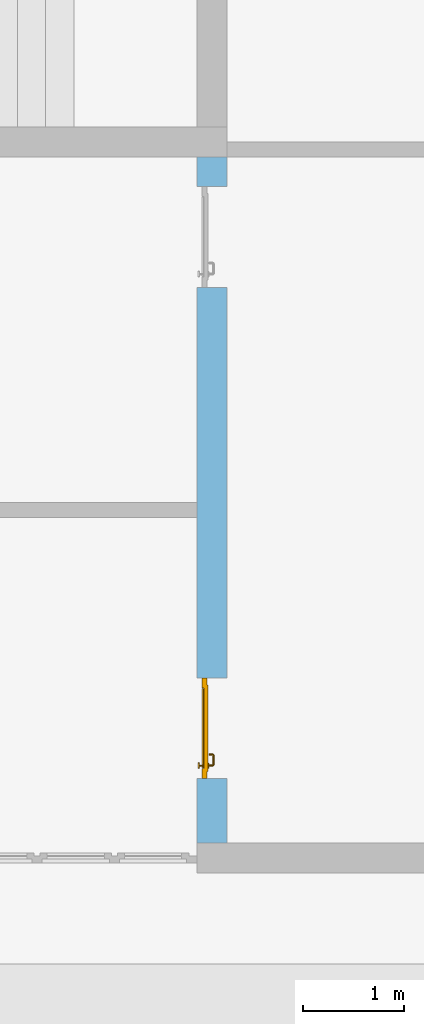
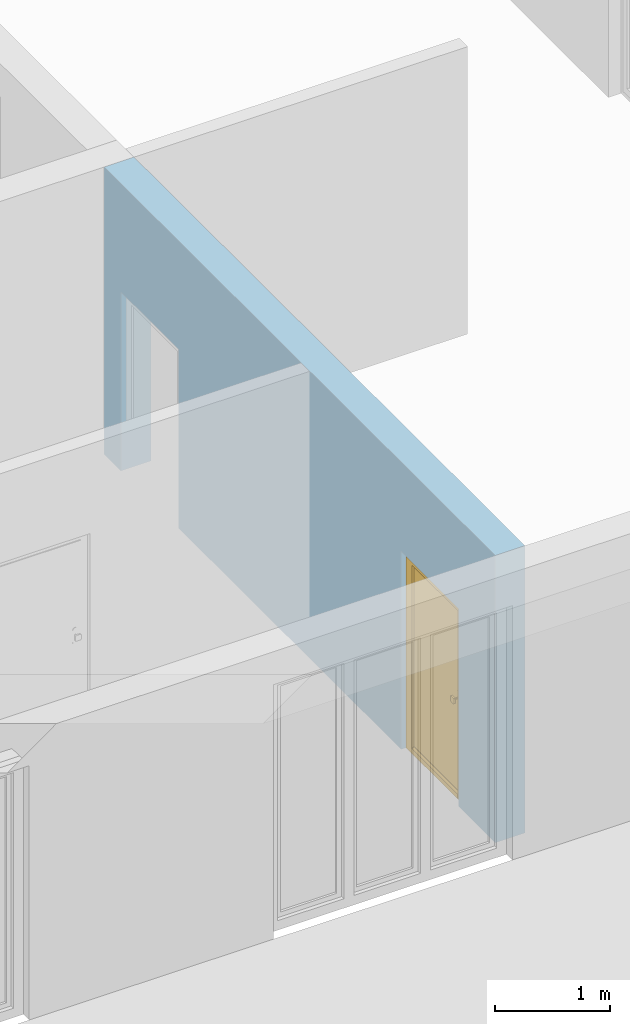
# One storey, part 8 of 23: 1 door, 2 openings, plus 1 element that does not belong to this part.
"""IFC4 building model written with IfcOpenShell, lengths in metres."""

from ifc_helpers import new_model, entity, si_unit, converted_unit, derived_unit, direction, frame, origin_with_axes, place, context, subcontext, project, spatial, polygons, source, transform, mapped, material, type_object, element, fill, save


model = new_model("IFC4")

# Units and contexts
model_context = context("Model", 3, precision=1e-05, world=origin_with_axes(), true_north=direction((0.0, 1.0)))
body_context = subcontext(model_context, "Body", "Model", "MODEL_VIEW")
ifc_project = project(units=[si_unit("LENGTHUNIT", "METRE"), si_unit("AREAUNIT", "SQUARE_METRE"), si_unit("VOLUMEUNIT", "CUBIC_METRE"), converted_unit("PLANEANGLEUNIT", "DEGREE", entity("IfcPlaneAngleMeasure", 0.0174532925199), si_unit("PLANEANGLEUNIT", "RADIAN"), dimensions=[0, 0, 0, 0, 0, 0, 0]), converted_unit("TIMEUNIT", "Year", entity("IfcTimeMeasure", 31556926.0), si_unit("TIMEUNIT", "SECOND"), dimensions=[0, 0, 1, 0, 0, 0, 0]), si_unit("MASSUNIT", "GRAM", prefix="KILO"), si_unit("THERMODYNAMICTEMPERATUREUNIT", "DEGREE_CELSIUS"), si_unit("LUMINOUSINTENSITYUNIT", "LUMEN"), si_unit("ENERGYUNIT", "JOULE", prefix="MEGA"), derived_unit("THERMALCONDUCTANCEUNIT", [(si_unit("POWERUNIT", "WATT"), 1), (si_unit("LENGTHUNIT", "METRE"), -1), (si_unit("THERMODYNAMICTEMPERATUREUNIT", "KELVIN"), -1)]), derived_unit("SPECIFICHEATCAPACITYUNIT", [(si_unit("ENERGYUNIT", "JOULE"), 1), (si_unit("MASSUNIT", "GRAM", prefix="KILO"), -1), (si_unit("THERMODYNAMICTEMPERATUREUNIT", "KELVIN"), -1)]), derived_unit("MASSDENSITYUNIT", [(si_unit("MASSUNIT", "GRAM", prefix="KILO"), 1), (si_unit("VOLUMEUNIT", "CUBIC_METRE"), -1)])], contexts=[model_context])

# Site, building, storey
site_placement = place(None, origin_with_axes())
site = spatial("IfcSite", under=ifc_project, at=site_placement, CompositionType="ELEMENT")
building_placement = place(site_placement, origin_with_axes())
building = spatial("IfcBuilding", under=site, at=building_placement, CompositionType="ELEMENT")
storey_placement = place(building_placement, origin_with_axes())
storey = spatial("IfcBuildingStorey", under=building, at=storey_placement, Name="0. Geschoss", CompositionType="ELEMENT", Elevation=0.0)

# Wall, openings, door
ifc_material = material()
wall_type = type_object("IfcWallType", Name="300", PredefinedType="NOTDEFINED")
wall_placement = place(storey_placement, frame((2.6878006196, -2.52881223104, 0.0), z_axis=(0.0, 0.0, 1.0), x_axis=(0.0, -1.0, 0.0)))
wall = element("IfcWall", 1, at=wall_placement, inside=storey, type_object=wall_type, material=ifc_material, Name="Wand-001", PredefinedType="NOTDEFINED", context=body_context, shape_type="Tessellation", body=[
    polygons([(6.46366655835, 0.15, 0.0), (6.46366655835, 0.15, 2.1), (5.46366655835, 0.15, 2.1), (5.46366655835, 0.15, 0.0), (1.59031106762, 0.15, 0.0), (1.59031106762, 0.15, 1.9), (0.590311067622, 0.15, 1.9), (0.590311067622, 0.15, 0.0), (0.3, 0.15, 0.0), (0.3, 0.15, 3.05), (7.1, 0.15, 3.05), (7.1, 0.15, 0.0), (6.46366655835, -0.1, 0.0), (6.46366655835, -0.15, 0.0), (6.46366655835, -0.15, 2.1), (5.46366655835, -0.15, 2.1), (5.46366655835, -0.1, 0.0), (5.46366655835, -0.15, 0.0), (1.59031106762, -0.15, 0.0), (1.59031106762, -0.15, 1.9), (0.590311067622, -0.15, 1.9), (0.590311067622, -0.15, 0.0), (0.3, -0.15, 0.0), (0.3, -0.15, 3.05), (7.1, -0.15, 3.05), (7.1, -0.15, 0.0)], [[[1, 2, 3, 4, 5, 6, 7, 8, 9, 10, 11, 12]], [[2, 1, 13, 14, 15]], [[3, 2, 15, 16]], [[17, 4, 3, 16, 18]], [[4, 17, 18, 19, 5]], [[19, 20, 6, 5]], [[20, 21, 7, 6]], [[21, 22, 8, 7]], [[23, 9, 8, 22]], [[23, 24, 10, 9]], [[25, 11, 10, 24]], [[12, 11, 25, 26]], [[13, 1, 12, 26, 14]], [[19, 18, 16, 15, 14, 26, 25, 24, 23, 22, 21, 20]]], closed=True),
])
opening_1_placement = place(wall_placement, frame((1.09031106762, 0.0, 0.0), z_axis=(0.0, 0.0, 1.0), x_axis=(1.0, 0.0, 0.0)))
element("IfcOpeningElement", 2, at=opening_1_placement, cuts=wall, context=body_context, identifier="Reference", shape_type="Tessellation", body=[
    polygons([(0.5, -0.1, 0.0), (0.5, -0.1, 1.9), (0.5, -0.151, 1.9), (0.5, -0.151, 0.0), (0.5, 0.151, 0.0), (0.5, 0.151, 1.9), (-0.5, -0.1, 1.9), (-0.5, -0.151, 1.9), (-0.5, 0.151, 1.9), (-0.5, -0.151, 0.0), (-0.5, -0.1, 0.0), (-0.5, 0.151, 0.0)], [[[1, 2, 3, 4]], [[2, 1, 5, 6]], [[7, 8, 3, 2, 6, 9]], [[8, 10, 4, 3]], [[1, 4, 10, 11, 12, 5]], [[6, 5, 12, 9]], [[7, 11, 10, 8]], [[11, 7, 9, 12]]], closed=True),
])
opening_2_placement = place(wall_placement, frame((5.96366655835, 0.0, 0.0), z_axis=(0.0, 0.0, 1.0), x_axis=(1.0, 0.0, 0.0)))
opening_2 = element("IfcOpeningElement", 3, at=opening_2_placement, cuts=wall, context=body_context, identifier="Reference", shape_type="Tessellation", body=[
    polygons([(0.5, -0.1, 0.0), (0.5, -0.1, 2.1), (0.5, -0.151, 2.1), (0.5, -0.151, 0.0), (0.5, 0.151, 0.0), (0.5, 0.151, 2.1), (-0.5, -0.1, 2.1), (-0.5, -0.151, 2.1), (-0.5, 0.151, 2.1), (-0.5, -0.151, 0.0), (-0.5, -0.1, 0.0), (-0.5, 0.151, 0.0)], [[[1, 2, 3, 4]], [[2, 1, 5, 6]], [[7, 8, 3, 2, 6, 9]], [[8, 10, 4, 3]], [[1, 4, 10, 11, 12, 5]], [[6, 5, 12, 9]], [[7, 11, 10, 8]], [[11, 7, 9, 12]]], closed=True),
])
door_type = type_object("IfcDoorType", Name="Eingang 01 1-Fl 26", OperationType="SINGLE_SWING_LEFT", PredefinedType="DOOR")
shared_shape = source(origin_with_axes(), body_context, "Body", "Tessellation", [
    polygons([(-0.5, -0.05, 0.0), (-0.5, -0.05, 2.1), (-0.5, -0.03, 2.1), (-0.5, -0.03, 0.0), (-0.4, -0.05, 0.0), (-0.4, -0.05, 2.0), (-0.1301, -0.05, 2.0), (-0.0001, -0.05, 2.0), (0.4, -0.05, 2.0), (0.4, -0.05, 0.0), (0.5, -0.05, 0.0), (0.5, -0.05, 2.1), (0.5, -0.03, 2.1), (0.5, -0.03, 0.0), (0.4, -0.03, 0.0), (0.4, -0.03, 2.0), (-0.0001, -0.03, 2.0), (-0.1301, -0.03, 2.0), (-0.4, -0.03, 2.0), (-0.4, -0.03, 0.0)], [[[1, 2, 3, 4]], [[1, 5, 6, 7, 8, 9, 10, 11, 12, 2]], [[2, 12, 13, 3]], [[4, 3, 13, 14, 15, 16, 17, 18, 19, 20]], [[5, 1, 4, 20]], [[6, 5, 20, 19]], [[7, 6, 19, 18]], [[8, 7, 18, 17]], [[9, 8, 17, 16]], [[10, 9, 16, 15]], [[11, 10, 15, 14]], [[12, 11, 14, 13]]], closed=True),
    polygons([(-0.5, -0.03, 0.0), (-0.5, -0.03, 2.1), (-0.5, 0.0, 2.1), (-0.5, 0.0, 0.0), (-0.43, -0.03, 0.0), (-0.43, -0.03, 2.03), (-0.1001, -0.03, 2.03), (-0.0301, -0.03, 2.03), (0.43, -0.03, 2.03), (0.43, -0.03, 0.0), (0.5, -0.03, 0.0), (0.5, -0.03, 2.1), (0.5, 0.0, 2.1), (0.5, 0.0, 0.0), (0.43, 0.0, 0.0), (0.43, 0.0, 2.03), (-0.0301, 0.0, 2.03), (-0.1001, 0.0, 2.03), (-0.43, 0.0, 2.03), (-0.43, 0.0, 0.0)], [[[1, 2, 3, 4]], [[1, 5, 6, 7, 8, 9, 10, 11, 12, 2]], [[2, 12, 13, 3]], [[4, 3, 13, 14, 15, 16, 17, 18, 19, 20]], [[5, 1, 4, 20]], [[6, 5, 20, 19]], [[7, 6, 19, 18]], [[8, 7, 18, 17]], [[9, 8, 17, 16]], [[10, 9, 16, 15]], [[11, 10, 15, 14]], [[12, 11, 14, 13]]], closed=True),
    polygons([(-0.43, 0.01, 0.0), (-0.43, 0.01, 2.03), (0.43, 0.01, 2.03), (0.43, 0.01, 0.0), (-0.43, -0.03, 0.0), (-0.43, -0.03, 2.03), (0.43, -0.03, 2.03), (0.43, -0.03, 0.0)], [[[1, 2, 3, 4]], [[1, 5, 6, 2]], [[2, 6, 7, 3]], [[3, 7, 8, 4]], [[4, 8, 5, 1]], [[8, 7, 6, 5]]], closed=True),
    polygons([(-0.395, -0.05, 0.0), (0.395, -0.05, 0.0), (0.395, -0.05, 0.05), (-0.395, -0.05, 0.05), (-0.395, -0.03, 0.0), (0.395, -0.03, 0.0), (0.395, -0.03, 0.07), (0.395, -0.035, 0.07), (-0.395, -0.035, 0.07), (-0.395, -0.03, 0.07)], [[[1, 2, 3, 4]], [[5, 6, 2, 1]], [[2, 6, 7, 8, 3]], [[4, 3, 8, 9]], [[1, 4, 9, 10, 5]], [[10, 7, 6, 5]], [[9, 8, 7, 10]]], closed=True),
    polygons([(0.3835, 0.02, 1.0733826859), (0.37, 0.02, 1.077), (0.37, 0.0199, 1.077), (0.3835, 0.0199, 1.0733826859), (0.393382685902, 0.02, 1.0635), (0.397, 0.02, 1.05), (0.393382685902, 0.02, 1.0365), (0.3835, 0.02, 1.0266173141), (0.37, 0.02, 1.023), (0.3565, 0.02, 1.0266173141), (0.346617314098, 0.02, 1.0365), (0.343, 0.02, 1.05), (0.346617314098, 0.02, 1.0635), (0.3565, 0.02, 1.0733826859), (0.3565, 0.0199, 1.0733826859), (0.37, 0.0101, 1.077), (0.3835, 0.0101, 1.0733826859), (0.393382685902, 0.0199, 1.0635), (0.397, 0.0199, 1.05), (0.393382685902, 0.0199, 1.0365), (0.3835, 0.0199, 1.0266173141), (0.37, 0.0199, 1.023), (0.3565, 0.0199, 1.0266173141), (0.346617314098, 0.0199, 1.0365), (0.343, 0.0199, 1.05), (0.346617314098, 0.0199, 1.0635), (0.3565, 0.0101, 1.0733826859), (0.37, 0.01, 1.077), (0.3835, 0.01, 1.0733826859), (0.393382685902, 0.0101, 1.0635), (0.397, 0.0101, 1.05), (0.393382685902, 0.0101, 1.0365), (0.3835, 0.0101, 1.0266173141), (0.37, 0.0101, 1.023), (0.3565, 0.0101, 1.0266173141), (0.346617314098, 0.0101, 1.0365), (0.343, 0.0101, 1.05), (0.346617314098, 0.0101, 1.0635), (0.3565, 0.01, 1.0733826859), (0.346617314098, 0.01, 1.0635), (0.343, 0.01, 1.05), (0.346617314098, 0.01, 1.0365), (0.3565, 0.01, 1.0266173141), (0.37, 0.01, 1.023), (0.3835, 0.01, 1.0266173141), (0.393382685902, 0.01, 1.0365), (0.397, 0.01, 1.05), (0.393382685902, 0.01, 1.0635)], [[[1, 2, 3, 4]], [[2, 1, 5, 6, 7, 8, 9, 10, 11, 12, 13, 14]], [[2, 14, 15, 3]], [[4, 3, 16, 17]], [[5, 1, 4, 18]], [[6, 5, 18, 19]], [[7, 6, 19, 20]], [[8, 7, 20, 21]], [[9, 8, 21, 22]], [[10, 9, 22, 23]], [[11, 10, 23, 24]], [[12, 11, 24, 25]], [[13, 12, 25, 26]], [[14, 13, 26, 15]], [[3, 15, 27, 16]], [[17, 16, 28, 29]], [[18, 4, 17, 30]], [[19, 18, 30, 31]], [[20, 19, 31, 32]], [[21, 20, 32, 33]], [[22, 21, 33, 34]], [[23, 22, 34, 35]], [[24, 23, 35, 36]], [[25, 24, 36, 37]], [[26, 25, 37, 38]], [[15, 26, 38, 27]], [[16, 27, 39, 28]], [[28, 39, 40, 41, 42, 43, 44, 45, 46, 47, 48, 29]], [[30, 17, 29, 48]], [[31, 30, 48, 47]], [[32, 31, 47, 46]], [[33, 32, 46, 45]], [[34, 33, 45, 44]], [[35, 34, 44, 43]], [[36, 35, 43, 42]], [[37, 36, 42, 41]], [[38, 37, 41, 40]], [[27, 38, 40, 39]]], closed=True),
    polygons([(0.362532169224, 0.019, 0.959692280177), (0.363279754556, 0.019, 0.961639806549), (0.35705, 0.019, 0.972430057958), (0.347569942042, 0.019, 0.96295), (0.365, 0.019, 0.952886751346), (0.365, 0.019, 0.9544), (0.362532169224, 0.02, 0.959692280177), (0.363279754556, 0.02, 0.961639806549), (0.364624817685, 0.02, 0.965143815798), (0.364624817685, 0.019, 0.965143815798), (0.37, 0.019, 0.967425445323), (0.37, 0.019, 0.9759), (0.357, 0.019, 0.972516660498), (0.347483339502, 0.019, 0.963), (0.365, 0.019, 0.95), (0.3441, 0.019, 0.95), (0.365, 0.019, 0.947113248654), (0.365, 0.019, 0.941339745962), (0.365, 0.019, 0.9375), (0.365, 0.02, 0.9375), (0.365, 0.02, 0.941339745962), (0.365, 0.02, 0.947113248654), (0.365, 0.02, 0.95), (0.365, 0.02, 0.952886751346), (0.365, 0.02, 0.9544), (0.346703916638, 0.02, 0.96345), (0.35655, 0.02, 0.973296083362), (0.37, 0.02, 0.9769), (0.37, 0.02, 0.967425445323), (0.375375182315, 0.019, 0.965143815798), (0.376720245444, 0.019, 0.961639806549), (0.38295, 0.019, 0.972430057958), (0.37, 0.019, 0.976), (0.357, 0.0189, 0.972516660498), (0.347483339502, 0.0189, 0.963), (0.344, 0.019, 0.95), (0.347569942042, 0.019, 0.93705), (0.35705, 0.019, 0.927569942042), (0.37, 0.019, 0.9241), (0.37, 0.019, 0.9325), (0.366464466094, 0.019, 0.933964466094), (0.366464466094, 0.02, 0.933964466094), (0.37, 0.02, 0.9231), (0.35655, 0.02, 0.926703916638), (0.37, 0.02, 0.9325), (0.346703916638, 0.02, 0.93655), (0.3431, 0.02, 0.95), (0.346617314098, 0.02, 0.9635), (0.3565, 0.02, 0.973382685902), (0.37, 0.02, 0.977), (0.375375182315, 0.02, 0.965143815798), (0.38345, 0.02, 0.973296083362), (0.376720245444, 0.02, 0.961639806549), (0.377467830776, 0.02, 0.959692280177), (0.377467830776, 0.019, 0.959692280177), (0.375, 0.019, 0.9544), (0.375, 0.019, 0.952886751346), (0.392430057958, 0.019, 0.96295), (0.383, 0.019, 0.972516660498), (0.37, 0.0189, 0.976), (0.357, 0.0101, 0.972516660498), (0.347483339502, 0.0101, 0.963), (0.344, 0.0189, 0.95), (0.347483339502, 0.019, 0.937), (0.357, 0.019, 0.927483339502), (0.37, 0.019, 0.924), (0.38295, 0.019, 0.927569942042), (0.375, 0.019, 0.941339745962), (0.375, 0.019, 0.9375), (0.373535533906, 0.019, 0.933964466094), (0.37, 0.02, 0.923), (0.3565, 0.02, 0.926617314098), (0.38345, 0.02, 0.926703916638), (0.373535533906, 0.02, 0.933964466094), (0.375, 0.02, 0.9375), (0.375, 0.02, 0.941339745962), (0.346617314098, 0.02, 0.9365), (0.343, 0.02, 0.95), (0.346617314098, 0.0199, 0.9635), (0.3565, 0.0199, 0.973382685902), (0.37, 0.0199, 0.977), (0.3835, 0.02, 0.973382685902), (0.393296083362, 0.02, 0.96345), (0.375, 0.02, 0.952886751346), (0.375, 0.02, 0.9544), (0.375, 0.02, 0.95), (0.375, 0.02, 0.947113248654), (0.375, 0.019, 0.947113248654), (0.375, 0.019, 0.95), (0.3959, 0.019, 0.95), (0.392516660498, 0.019, 0.963), (0.383, 0.0189, 0.972516660498), (0.37, 0.0101, 0.976), (0.357, 0.01, 0.972516660498), (0.347483339502, 0.01, 0.963), (0.344, 0.0101, 0.95), (0.347483339502, 0.0189, 0.937), (0.357, 0.0189, 0.927483339502), (0.37, 0.0189, 0.924), (0.383, 0.019, 0.927483339502), (0.392430057958, 0.019, 0.93705), (0.37, 0.0199, 0.923), (0.3565, 0.0199, 0.926617314098), (0.3835, 0.02, 0.926617314098), (0.393296083362, 0.02, 0.93655), (0.346617314098, 0.0199, 0.9365), (0.343, 0.0199, 0.95), (0.346617314098, 0.0101, 0.9635), (0.3565, 0.0101, 0.973382685902), (0.37, 0.0101, 0.977), (0.3835, 0.0199, 0.973382685902), (0.393382685902, 0.02, 0.9635), (0.3969, 0.02, 0.95), (0.396, 0.019, 0.95), (0.392516660498, 0.0189, 0.963), (0.383, 0.0101, 0.972516660498), (0.37, 0.01, 0.976), (0.35695, 0.01, 0.972603263039), (0.347396736961, 0.01, 0.96305), (0.344, 0.01, 0.95), (0.347483339502, 0.0101, 0.937), (0.357, 0.0101, 0.927483339502), (0.37, 0.0101, 0.924), (0.383, 0.0189, 0.927483339502), (0.392516660498, 0.019, 0.937), (0.37, 0.0101, 0.923), (0.3565, 0.0101, 0.926617314098), (0.3835, 0.0199, 0.926617314098), (0.393382685902, 0.02, 0.9365), (0.346617314098, 0.0101, 0.9365), (0.343, 0.0101, 0.95), (0.346617314098, 0.01, 0.9635), (0.3565, 0.01, 0.973382685902), (0.37, 0.01, 0.977), (0.3835, 0.0101, 0.973382685902), (0.393382685902, 0.0199, 0.9635), (0.397, 0.02, 0.95), (0.396, 0.0189, 0.95), (0.392516660498, 0.0101, 0.963), (0.383, 0.01, 0.972516660498), (0.37, 0.01, 0.9761), (0.35655, 0.01, 0.973296083362), (0.346703916638, 0.01, 0.96345), (0.3439, 0.01, 0.95), (0.347483339502, 0.01, 0.937), (0.357, 0.01, 0.927483339502), (0.37, 0.01, 0.924), (0.383, 0.0101, 0.927483339502), (0.392516660498, 0.0189, 0.937), (0.37, 0.01, 0.923), (0.3565, 0.01, 0.926617314098), (0.3835, 0.0101, 0.926617314098), (0.393382685902, 0.0199, 0.9365), (0.346617314098, 0.01, 0.9365), (0.343, 0.01, 0.95), (0.37, 0.01, 0.9769), (0.3835, 0.01, 0.973382685902), (0.393382685902, 0.0101, 0.9635), (0.397, 0.0199, 0.95), (0.396, 0.0101, 0.95), (0.392516660498, 0.01, 0.963), (0.38305, 0.01, 0.972603263039), (0.3431, 0.01, 0.95), (0.347396736961, 0.01, 0.93695), (0.35695, 0.01, 0.927396736961), (0.37, 0.01, 0.9239), (0.383, 0.01, 0.927483339502), (0.392516660498, 0.0101, 0.937), (0.37, 0.01, 0.9231), (0.35655, 0.01, 0.926703916638), (0.3835, 0.01, 0.926617314098), (0.393382685902, 0.0101, 0.9365), (0.346703916638, 0.01, 0.93655), (0.38345, 0.01, 0.973296083362), (0.393382685902, 0.01, 0.9635), (0.397, 0.0101, 0.95), (0.396, 0.01, 0.95), (0.392603263039, 0.01, 0.96305), (0.38305, 0.01, 0.927396736961), (0.392516660498, 0.01, 0.937), (0.38345, 0.01, 0.926703916638), (0.393382685902, 0.01, 0.9365), (0.393296083362, 0.01, 0.96345), (0.397, 0.01, 0.95), (0.3961, 0.01, 0.95), (0.392603263039, 0.01, 0.93695), (0.393296083362, 0.01, 0.93655), (0.3969, 0.01, 0.95)], [[[1, 2, 3, 4, 5, 6]], [[1, 7, 8, 9, 10, 2]], [[10, 11, 12, 3, 2]], [[4, 3, 13, 14]], [[15, 5, 4, 16]], [[6, 5, 15, 17, 18, 19, 20, 21, 22, 23, 24, 25]], [[6, 25, 7, 1]], [[7, 25, 24, 26, 27, 8]], [[9, 8, 27, 28, 29]], [[10, 9, 29, 11]], [[30, 31, 32, 12, 11]], [[3, 12, 33, 13]], [[14, 13, 34, 35]], [[16, 4, 14, 36]], [[17, 15, 16, 37]], [[18, 17, 37, 38]], [[38, 39, 40, 41, 19, 18]], [[19, 41, 42, 20]], [[43, 44, 21, 20, 42, 45]], [[22, 21, 44, 46]], [[23, 22, 46, 47]], [[24, 23, 47, 26]], [[48, 49, 27, 26]], [[49, 50, 28, 27]], [[51, 29, 28, 52, 53]], [[11, 29, 51, 30]], [[30, 51, 53, 54, 55, 31]], [[55, 56, 57, 58, 32, 31]], [[12, 32, 59, 33]], [[13, 33, 60, 34]], [[35, 34, 61, 62]], [[36, 14, 35, 63]], [[37, 16, 36, 64]], [[38, 37, 64, 65]], [[39, 38, 65, 66]], [[39, 67, 68, 69, 70, 40]], [[41, 40, 45, 42]], [[71, 72, 44, 43]], [[73, 43, 45, 74, 75, 76]], [[72, 77, 46, 44]], [[77, 78, 47, 46]], [[78, 48, 26, 47]], [[79, 80, 49, 48]], [[80, 81, 50, 49]], [[50, 82, 52, 28]], [[54, 53, 52, 83, 84, 85]], [[55, 54, 85, 56]], [[85, 84, 86, 87, 76, 75, 69, 68, 88, 89, 57, 56]], [[57, 89, 90, 58]], [[32, 58, 91, 59]], [[33, 59, 92, 60]], [[34, 60, 93, 61]], [[62, 61, 94, 95]], [[63, 35, 62, 96]], [[64, 36, 63, 97]], [[65, 64, 97, 98]], [[66, 65, 98, 99]], [[67, 39, 66, 100]], [[88, 68, 67, 101]], [[70, 69, 75, 74]], [[40, 70, 74, 45]], [[102, 103, 72, 71]], [[104, 71, 43, 73]], [[76, 87, 105, 73]], [[103, 106, 77, 72]], [[106, 107, 78, 77]], [[107, 79, 48, 78]], [[108, 109, 80, 79]], [[109, 110, 81, 80]], [[81, 111, 82, 50]], [[82, 112, 83, 52]], [[86, 84, 83, 113]], [[87, 86, 113, 105]], [[89, 88, 101, 90]], [[58, 90, 114, 91]], [[59, 91, 115, 92]], [[60, 92, 116, 93]], [[61, 93, 117, 94]], [[95, 94, 118, 119]], [[96, 62, 95, 120]], [[97, 63, 96, 121]], [[98, 97, 121, 122]], [[99, 98, 122, 123]], [[100, 66, 99, 124]], [[101, 67, 100, 125]], [[126, 127, 103, 102]], [[128, 102, 71, 104]], [[129, 104, 73, 105]], [[127, 130, 106, 103]], [[130, 131, 107, 106]], [[131, 108, 79, 107]], [[132, 133, 109, 108]], [[133, 134, 110, 109]], [[110, 135, 111, 81]], [[111, 136, 112, 82]], [[112, 137, 113, 83]], [[137, 129, 105, 113]], [[90, 101, 125, 114]], [[91, 114, 138, 115]], [[92, 115, 139, 116]], [[93, 116, 140, 117]], [[94, 117, 141, 118]], [[119, 118, 142, 143]], [[120, 95, 119, 144]], [[121, 96, 120, 145]], [[122, 121, 145, 146]], [[123, 122, 146, 147]], [[124, 99, 123, 148]], [[125, 100, 124, 149]], [[150, 151, 127, 126]], [[152, 126, 102, 128]], [[153, 128, 104, 129]], [[151, 154, 130, 127]], [[154, 155, 131, 130]], [[155, 132, 108, 131]], [[143, 142, 133, 132]], [[142, 156, 134, 133]], [[134, 157, 135, 110]], [[135, 158, 136, 111]], [[136, 159, 137, 112]], [[159, 153, 129, 137]], [[114, 125, 149, 138]], [[115, 138, 160, 139]], [[116, 139, 161, 140]], [[117, 140, 162, 141]], [[118, 141, 156, 142]], [[144, 119, 143, 163]], [[145, 120, 144, 164]], [[146, 145, 164, 165]], [[147, 146, 165, 166]], [[148, 123, 147, 167]], [[149, 124, 148, 168]], [[169, 170, 151, 150]], [[171, 150, 126, 152]], [[172, 152, 128, 153]], [[170, 173, 154, 151]], [[173, 163, 155, 154]], [[163, 143, 132, 155]], [[156, 174, 157, 134]], [[157, 175, 158, 135]], [[158, 176, 159, 136]], [[176, 172, 153, 159]], [[138, 149, 168, 160]], [[139, 160, 177, 161]], [[140, 161, 178, 162]], [[141, 162, 174, 156]], [[164, 144, 163, 173]], [[165, 164, 173, 170]], [[166, 165, 170, 169]], [[167, 147, 166, 179]], [[168, 148, 167, 180]], [[181, 169, 150, 171]], [[182, 171, 152, 172]], [[174, 183, 175, 157]], [[175, 184, 176, 158]], [[184, 182, 172, 176]], [[160, 168, 180, 177]], [[161, 177, 185, 178]], [[162, 178, 183, 174]], [[179, 166, 169, 181]], [[180, 167, 179, 186]], [[187, 181, 171, 182]], [[183, 188, 184, 175]], [[188, 187, 182, 184]], [[177, 180, 186, 185]], [[178, 185, 188, 183]], [[186, 179, 181, 187]], [[185, 186, 187, 188]]], closed=True),
    polygons([(0.38, 0.02, 1.05), (0.377071067812, 0.02, 1.04292893219), (0.377071067812, 0.050696439392, 1.04292893219), (0.38, 0.0509849140336, 1.05), (0.37, 0.02, 1.04), (0.37, 0.05, 1.04), (0.375518993221, 0.0584992452783, 1.04292893219), (0.378277987014, 0.0596420579258, 1.05), (0.377071067812, 0.02, 1.05707106781), (0.377071067812, 0.050696439392, 1.05707106781), (0.362928932188, 0.02, 1.04292893219), (0.362928932188, 0.049303560608, 1.04292893219), (0.368858192988, 0.0557402514855, 1.04), (0.370704557509, 0.0657045575088, 1.04292893219), (0.372816199938, 0.0678161999379, 1.05), (0.375518993221, 0.0584992452783, 1.05707106781), (0.37, 0.02, 1.06), (0.37, 0.05, 1.06), (0.36, 0.02, 1.05), (0.36, 0.0490150859664, 1.05), (0.362197392755, 0.0529812576926, 1.04292893219), (0.365606601718, 0.0606066017178, 1.04), (0.363499245278, 0.0705189932208, 1.04292893219), (0.364642057926, 0.0732779870137, 1.05), (0.370704557509, 0.0657045575088, 1.05707106781), (0.368858192988, 0.0557402514855, 1.06), (0.362928932188, 0.02, 1.05707106781), (0.362928932188, 0.049303560608, 1.05707106781), (0.359438398962, 0.0518384450452, 1.05), (0.360508645927, 0.0555086459268, 1.04292893219), (0.360740251485, 0.0638581929877, 1.04), (0.355696439392, 0.0720710678119, 1.04292893219), (0.355984914034, 0.075, 1.05), (0.363499245278, 0.0705189932208, 1.05707106781), (0.365606601718, 0.0606066017178, 1.06), (0.362197392755, 0.0529812576926, 1.05707106781), (0.358397003498, 0.0533970034977, 1.05), (0.357981257693, 0.0571973927545, 1.04292893219), (0.355, 0.065, 1.04), (0.274303560608, 0.0720710678119, 1.04292893219), (0.274015085966, 0.075, 1.05), (0.355696439392, 0.0720710678119, 1.05707106781), (0.360740251485, 0.0638581929877, 1.06), (0.360508645927, 0.0555086459268, 1.05707106781), (0.356838445045, 0.0544383989617, 1.05), (0.354303560608, 0.0579289321881, 1.04292893219), (0.275, 0.065, 1.04), (0.266500754722, 0.0705189932208, 1.04292893219), (0.265357942074, 0.0732779870137, 1.05), (0.274303560608, 0.0720710678119, 1.05707106781), (0.355, 0.065, 1.06), (0.357981257693, 0.0571973927545, 1.05707106781), (0.354015085966, 0.055, 1.05), (0.275696439392, 0.0579289321881, 1.04292893219), (0.269259748515, 0.0638581929877, 1.04), (0.259295442491, 0.0657045575088, 1.04292893219), (0.257183800062, 0.0678161999379, 1.05), (0.266500754722, 0.0705189932208, 1.05707106781), (0.275, 0.065, 1.06), (0.354303560608, 0.0579289321881, 1.05707106781), (0.275984914034, 0.055, 1.05), (0.272018742307, 0.0571973927545, 1.04292893219), (0.264393398282, 0.0606066017178, 1.04), (0.254481006779, 0.0584992452783, 1.04292893219), (0.251722012986, 0.0596420579258, 1.05), (0.259295442491, 0.0657045575088, 1.05707106781), (0.269259748515, 0.0638581929877, 1.06), (0.275696439392, 0.0579289321881, 1.05707106781), (0.273161554955, 0.0544383989617, 1.05), (0.269491354073, 0.0555086459268, 1.04292893219), (0.261141807012, 0.0557402514855, 1.04), (0.252928932188, 0.050696439392, 1.04292893219), (0.25, 0.0509849140336, 1.05), (0.254481006779, 0.0584992452783, 1.05707106781), (0.264393398282, 0.0606066017178, 1.06), (0.272018742307, 0.0571973927545, 1.05707106781), (0.271602996502, 0.0533970034977, 1.05), (0.267802607245, 0.0529812576926, 1.04292893219), (0.26, 0.05, 1.04), (0.252928932188, 0.02, 1.04292893219), (0.25, 0.02, 1.05), (0.252928932188, 0.050696439392, 1.05707106781), (0.261141807012, 0.0557402514855, 1.06), (0.269491354073, 0.0555086459268, 1.05707106781), (0.270561601038, 0.0518384450452, 1.05), (0.267071067812, 0.049303560608, 1.04292893219), (0.26, 0.02, 1.04), (0.267071067812, 0.02, 1.04292893219), (0.27, 0.02, 1.05), (0.267071067812, 0.02, 1.05707106781), (0.26, 0.02, 1.06), (0.252928932188, 0.02, 1.05707106781), (0.26, 0.05, 1.06), (0.267802607245, 0.0529812576926, 1.05707106781), (0.27, 0.0490150859664, 1.05), (0.267071067812, 0.049303560608, 1.05707106781)], [[[1, 2, 3, 4]], [[2, 5, 6, 3]], [[4, 3, 7, 8]], [[9, 1, 4, 10]], [[5, 11, 12, 6]], [[3, 6, 13, 7]], [[8, 7, 14, 15]], [[10, 4, 8, 16]], [[17, 9, 10, 18]], [[11, 19, 20, 12]], [[6, 12, 21, 13]], [[7, 13, 22, 14]], [[15, 14, 23, 24]], [[16, 8, 15, 25]], [[18, 10, 16, 26]], [[27, 17, 18, 28]], [[19, 27, 28, 20]], [[12, 20, 29, 21]], [[13, 21, 30, 22]], [[14, 22, 31, 23]], [[24, 23, 32, 33]], [[25, 15, 24, 34]], [[26, 16, 25, 35]], [[28, 18, 26, 36]], [[20, 28, 36, 29]], [[21, 29, 37, 30]], [[22, 30, 38, 31]], [[23, 31, 39, 32]], [[33, 32, 40, 41]], [[34, 24, 33, 42]], [[35, 25, 34, 43]], [[36, 26, 35, 44]], [[29, 36, 44, 37]], [[30, 37, 45, 38]], [[31, 38, 46, 39]], [[32, 39, 47, 40]], [[41, 40, 48, 49]], [[42, 33, 41, 50]], [[43, 34, 42, 51]], [[44, 35, 43, 52]], [[37, 44, 52, 45]], [[38, 45, 53, 46]], [[39, 46, 54, 47]], [[40, 47, 55, 48]], [[49, 48, 56, 57]], [[50, 41, 49, 58]], [[51, 42, 50, 59]], [[52, 43, 51, 60]], [[45, 52, 60, 53]], [[46, 53, 61, 54]], [[47, 54, 62, 55]], [[48, 55, 63, 56]], [[57, 56, 64, 65]], [[58, 49, 57, 66]], [[59, 50, 58, 67]], [[60, 51, 59, 68]], [[53, 60, 68, 61]], [[54, 61, 69, 62]], [[55, 62, 70, 63]], [[56, 63, 71, 64]], [[65, 64, 72, 73]], [[66, 57, 65, 74]], [[67, 58, 66, 75]], [[68, 59, 67, 76]], [[61, 68, 76, 69]], [[62, 69, 77, 70]], [[63, 70, 78, 71]], [[64, 71, 79, 72]], [[73, 72, 80, 81]], [[74, 65, 73, 82]], [[75, 66, 74, 83]], [[76, 67, 75, 84]], [[69, 76, 84, 77]], [[70, 77, 85, 78]], [[71, 78, 86, 79]], [[72, 79, 87, 80]], [[81, 80, 87, 88, 89, 90, 91, 92]], [[82, 73, 81, 92]], [[83, 74, 82, 93]], [[84, 75, 83, 94]], [[77, 84, 94, 85]], [[78, 85, 95, 86]], [[79, 86, 88, 87]], [[86, 95, 89, 88]], [[95, 96, 90, 89]], [[96, 93, 91, 90]], [[93, 82, 92, 91]], [[94, 83, 93, 96]], [[85, 94, 96, 95]]], closed=False),
    polygons([(0.364696699141, -0.035, 1.04469669914), (0.3625, -0.035, 1.05), (0.364696699141, -0.035, 1.05530330086), (0.37, -0.035, 1.0575), (0.375303300859, -0.035, 1.05530330086), (0.3775, -0.035, 1.05), (0.375303300859, -0.035, 1.04469669914), (0.37, -0.035, 1.0425), (0.364696699141, -0.075, 1.04469669914), (0.3625, -0.075, 1.05), (0.364696699141, -0.075, 1.05530330086), (0.37, -0.075, 1.0575), (0.375303300859, -0.075, 1.05530330086), (0.3775, -0.075, 1.05), (0.375303300859, -0.075, 1.04469669914), (0.37, -0.075, 1.0425)], [[[1, 2, 3, 4, 5, 6, 7, 8]], [[1, 9, 10, 2]], [[2, 10, 11, 3]], [[3, 11, 12, 4]], [[4, 12, 13, 5]], [[5, 13, 14, 6]], [[6, 14, 15, 7]], [[7, 15, 16, 8]], [[8, 16, 9, 1]], [[9, 16, 15, 14, 13, 12, 11, 10]]], closed=True),
    polygons([(0.395, -0.03, 0.975), (0.395, -0.035, 0.975), (0.393096988313, -0.035, 0.965432914191), (0.393096988313, -0.03, 0.965432914191), (0.395, -0.03, 1.1), (0.395, -0.035, 1.1), (0.393096988313, -0.035, 1.10956708581), (0.38767766953, -0.035, 1.11767766953), (0.379567085809, -0.035, 1.12309698831), (0.37, -0.035, 1.125), (0.360432914191, -0.035, 1.12309698831), (0.35232233047, -0.035, 1.11767766953), (0.346903011687, -0.035, 1.10956708581), (0.345, -0.035, 1.1), (0.345, -0.035, 0.975), (0.346903011687, -0.035, 0.965432914191), (0.35232233047, -0.035, 0.95732233047), (0.360432914191, -0.035, 0.951903011687), (0.37, -0.035, 0.95), (0.379567085809, -0.035, 0.951903011687), (0.38767766953, -0.035, 0.95732233047), (0.38767766953, -0.03, 0.95732233047), (0.379567085809, -0.03, 0.951903011687), (0.37, -0.03, 0.95), (0.360432914191, -0.03, 0.951903011687), (0.35232233047, -0.03, 0.95732233047), (0.346903011687, -0.03, 0.965432914191), (0.345, -0.03, 0.975), (0.345, -0.03, 1.1), (0.346903011687, -0.03, 1.10956708581), (0.35232233047, -0.03, 1.11767766953), (0.360432914191, -0.03, 1.12309698831), (0.37, -0.03, 1.125), (0.379567085809, -0.03, 1.12309698831), (0.38767766953, -0.03, 1.11767766953), (0.393096988313, -0.03, 1.10956708581)], [[[1, 2, 3, 4]], [[5, 6, 2, 1]], [[2, 6, 7, 8, 9, 10, 11, 12, 13, 14, 15, 16, 17, 18, 19, 20, 21, 3]], [[4, 3, 21, 22]], [[1, 4, 22, 23, 24, 25, 26, 27, 28, 29, 30, 31, 32, 33, 34, 35, 36, 5]], [[36, 7, 6, 5]], [[35, 8, 7, 36]], [[34, 9, 8, 35]], [[33, 10, 9, 34]], [[32, 11, 10, 33]], [[31, 12, 11, 32]], [[30, 13, 12, 31]], [[29, 14, 13, 30]], [[28, 15, 14, 29]], [[27, 16, 15, 28]], [[26, 17, 16, 27]], [[25, 18, 17, 26]], [[24, 19, 18, 25]], [[23, 20, 19, 24]], [[22, 21, 20, 23]]], closed=True),
    polygons([(0.39, -0.075, 1.08), (0.39, -0.09, 1.08), (0.395, -0.09, 1.07866025404), (0.395, -0.075, 1.07866025404), (0.35, -0.075, 1.08), (0.35, -0.09, 1.08), (0.345, -0.09, 1.07866025404), (0.341339745962, -0.09, 1.075), (0.34, -0.09, 1.07), (0.34, -0.09, 1.03), (0.341339745962, -0.09, 1.025), (0.345, -0.09, 1.02133974596), (0.35, -0.09, 1.02), (0.39, -0.09, 1.02), (0.395, -0.09, 1.02133974596), (0.398660254038, -0.09, 1.025), (0.4, -0.09, 1.03), (0.4, -0.09, 1.07), (0.398660254038, -0.09, 1.075), (0.398660254038, -0.075, 1.075), (0.4, -0.075, 1.07), (0.4, -0.075, 1.03), (0.398660254038, -0.075, 1.025), (0.395, -0.075, 1.02133974596), (0.39, -0.075, 1.02), (0.35, -0.075, 1.02), (0.345, -0.075, 1.02133974596), (0.341339745962, -0.075, 1.025), (0.34, -0.075, 1.03), (0.34, -0.075, 1.07), (0.341339745962, -0.075, 1.075), (0.345, -0.075, 1.07866025404)], [[[1, 2, 3, 4]], [[5, 6, 2, 1]], [[2, 6, 7, 8, 9, 10, 11, 12, 13, 14, 15, 16, 17, 18, 19, 3]], [[4, 3, 19, 20]], [[1, 4, 20, 21, 22, 23, 24, 25, 26, 27, 28, 29, 30, 31, 32, 5]], [[32, 7, 6, 5]], [[31, 8, 7, 32]], [[30, 9, 8, 31]], [[29, 10, 9, 30]], [[28, 11, 10, 29]], [[27, 12, 11, 28]], [[26, 13, 12, 27]], [[25, 14, 13, 26]], [[24, 15, 14, 25]], [[23, 16, 15, 24]], [[22, 17, 16, 23]], [[21, 18, 17, 22]], [[20, 19, 18, 21]]], closed=True),
])
door_placement = place(opening_2_placement, frame((-0.4, 0.0, 0.0), z_axis=(0.0, 0.0, 1.0), x_axis=(1.0, 0.0, 0.0)))
door = element("IfcDoor", 4, at=door_placement, inside=storey, type_object=door_type, OverallHeight=2.1, OverallWidth=1.0, PredefinedType="DOOR", context=body_context, shape_type="MappedRepresentation", body=[
    mapped(shared_shape, transform((0.4, -0.05, 0.0))),
])
fill(opening_2, door)

save(model, "model.ifc")
